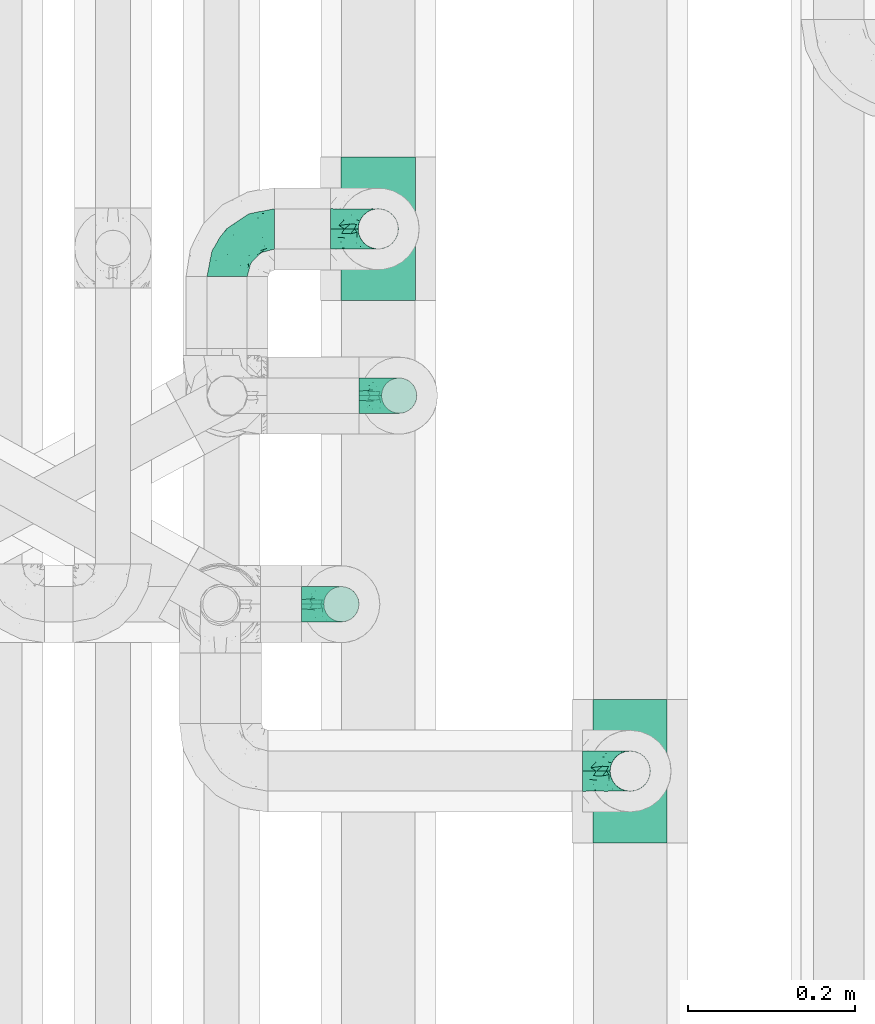
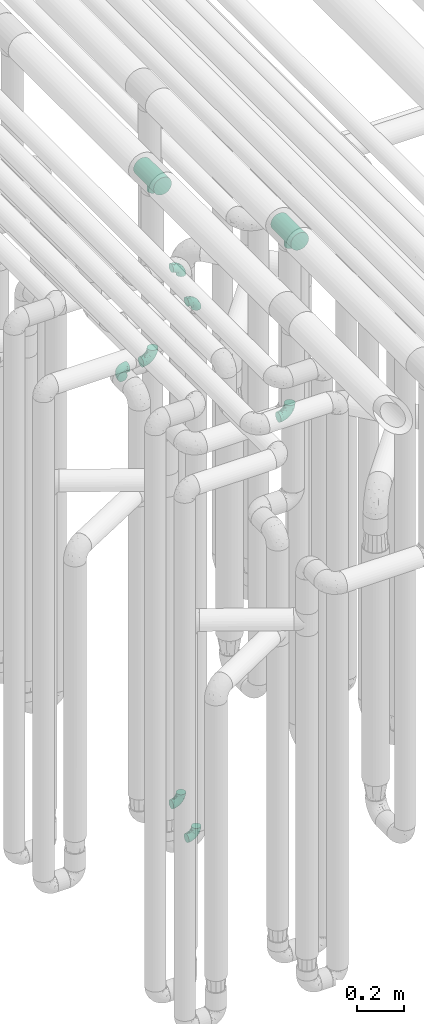
# One storey, part 616 of 827: 9 flow fittings.
"""IFC2X3 building model written with IfcOpenShell, lengths in millimetres."""

import ifcopenshell
import ifcopenshell.guid

model = None  # the IFC model being written
_history = None  # IfcOwnerHistory: only IFC2X3 demands one
_inside = {}  # id of a spatial element -> (the spatial element, [elements in it])
_under = {}  # id of a project, library or spatial element -> (it, [spatial elements below it])
_declared = {}  # id of a project -> (the project, [libraries it declares])
_typed = {}  # id of a type object -> (the type object, [elements of that type])
_made_of = {}  # id of a material, layer set ... -> (it, [elements and type objects made of it])


def new_model(schema):
    """Start an empty IFC model of exactly this schema.

    Asked for "IFC4X3", IfcOpenShell would pick the latest addendum, in which some entities
    have other attributes; the version numbers below select the first issue.
    IFC2X3 requires an IfcOwnerHistory on every rooted entity: one is made here for all.
    """
    global model, _history
    if schema == "IFC4X3":
        model = ifcopenshell.file(schema_version=(4, 3, 0, 0))
    else:
        model = ifcopenshell.file(schema=schema)
    _inside.clear()
    _under.clear()
    _declared.clear()
    _typed.clear()
    _made_of.clear()
    _history = None
    if model.schema == "IFC2X3":
        org = make("IfcOrganization", Name="unknown")
        user = make(
            "IfcPersonAndOrganization",
            ThePerson=make("IfcPerson", FamilyName="unknown"),
            TheOrganization=org,
        )
        app = make(
            "IfcApplication",
            ApplicationDeveloper=org,
            Version="unknown",
            ApplicationFullName="unknown",
            ApplicationIdentifier="unknown",
        )
        _history = make(
            "IfcOwnerHistory",
            OwningUser=user,
            OwningApplication=app,
            ChangeAction="ADDED",
            CreationDate=0,
        )
    return model


def make(cls, **values):
    """One entity of the class cls with the attributes given. An attribute that is None is left unset."""
    return model.create_entity(
        cls, **{name: value for name, value in values.items() if value is not None}
    )


def entity(cls, *values):
    """Any entity or typed value of the class cls, its attributes in the order of the schema. None: left unset."""
    e = model.create_entity(cls)
    for i, value in enumerate(values):
        if value is not None:
            e[i] = value
    return e


def rooted(cls, **values):
    """An entity with a GlobalId (a new one), such as an element, a storey or a relation."""
    return make(cls, GlobalId=ifcopenshell.guid.new(), OwnerHistory=_history, **values)


def si_unit(unit_type, name, prefix=None):
    """IfcSIUnit, for example si_unit("LENGTHUNIT", "METRE", prefix="MILLI")."""
    return make("IfcSIUnit", UnitType=unit_type, Prefix=prefix, Name=name)


def converted_unit(unit_type, name, factor, base, dimensions=None, offset=None):
    """IfcConversionBasedUnit, such as the inch: factor (a typed value) times the base unit."""
    return make(
        "IfcConversionBasedUnit"
        if offset is None
        else "IfcConversionBasedUnitWithOffset",
        ConversionOffset=offset,
        Dimensions=None
        if dimensions is None
        else entity("IfcDimensionalExponents", *dimensions),
        UnitType=unit_type,
        Name=name,
        ConversionFactor=make(
            "IfcMeasureWithUnit", ValueComponent=factor, UnitComponent=base
        ),
    )


def derived_unit(unit_type, elements):
    """IfcDerivedUnit: a product of units, each with its exponent."""
    return make(
        "IfcDerivedUnit",
        Elements=[
            make("IfcDerivedUnitElement", Unit=unit, Exponent=power)
            for unit, power in elements
        ],
        UnitType=unit_type,
    )


def assignment(units):
    """IfcUnitAssignment: the units of a project."""
    return None if units is None else make("IfcUnitAssignment", Units=units)


def point(xyz):
    """IfcCartesianPoint."""
    return None if xyz is None else make("IfcCartesianPoint", Coordinates=xyz)


def direction(xyz):
    """IfcDirection."""
    return None if xyz is None else make("IfcDirection", DirectionRatios=xyz)


def frame(location, z_axis=None, x_axis=None):
    """IfcAxis2Placement3D, a coordinate frame: its origin and axes. An axis left out is left unset."""
    return make(
        "IfcAxis2Placement3D",
        Location=point(location),
        Axis=direction(z_axis),
        RefDirection=direction(x_axis),
    )


def origin():
    """The frame at (0, 0, 0) with its axes left unset."""
    return frame((0.0, 0.0, 0.0))


def place(relative_to, where):
    """IfcLocalPlacement: puts the frame where relative to a parent placement (None: the world)."""
    return make(
        "IfcLocalPlacement", PlacementRelTo=relative_to, RelativePlacement=where
    )


def context(
    kind, dimensions, precision=None, world=None, true_north=None, identifier=None
):
    """IfcGeometricRepresentationContext, for example the 3D "Model" context."""
    return make(
        "IfcGeometricRepresentationContext",
        ContextIdentifier=identifier,
        ContextType=kind,
        CoordinateSpaceDimension=dimensions,
        Precision=precision,
        WorldCoordinateSystem=world,
        TrueNorth=true_north,
    )


def subcontext(parent, identifier, kind, view, scale=None):
    """IfcGeometricRepresentationSubContext, for example "Body" below "Model"."""
    return make(
        "IfcGeometricRepresentationSubContext",
        ContextIdentifier=identifier,
        ContextType=kind,
        ParentContext=parent,
        TargetScale=scale,
        TargetView=view,
    )


def project(units=None, contexts=None):
    """IfcProject with its units and contexts."""
    return rooted(
        "IfcProject",
        Name="project",
        RepresentationContexts=contexts,
        UnitsInContext=assignment(units),
    )


def spatial(cls, under=None, at=None, **own):
    """A site, building, storey or space (cls), placed at a placement, below another one or the project."""
    s = rooted(cls, ObjectPlacement=at, **own)
    if under is not None:
        _under.setdefault(under.id(), (under, []))[1].append(s)
    return s


def faces_of(points, faces, orient=None, outer=None):
    """IfcFace entities. A face is a list of loops; a loop is a list of indices into points, from 0.

    orient and outer hold one flag for each loop. By default every Orientation is true, the
    first loop of a face is its IfcFaceOuterBound and the others are IfcFaceBound.
    """
    made = []
    for i, loops in enumerate(faces):
        bounds = []
        for j, loop in enumerate(loops):
            is_outer = j == 0 if outer is None else outer[i][j]
            bounds.append(
                make(
                    "IfcFaceOuterBound" if is_outer else "IfcFaceBound",
                    Bound=make("IfcPolyLoop", Polygon=[points[k] for k in loop]),
                    Orientation=True if orient is None else orient[i][j],
                )
            )
        made.append(make("IfcFace", Bounds=bounds))
    return made


def faceted_brep(points, faces, orient=None, outer=None, voids=None):
    """IfcFacetedBrep: a solid bounded by flat faces; with voids (closed shells), ...WithVoids."""
    shared = [point(p) for p in points]
    hull = make("IfcClosedShell", CfsFaces=faces_of(shared, faces, orient, outer))
    if voids is None:
        return make("IfcFacetedBrep", Outer=hull)
    return make(
        "IfcFacetedBrepWithVoids",
        Outer=hull,
        Voids=[
            make(cls, CfsFaces=faces_of(shared, fs, o, b)) for cls, fs, o, b in voids
        ],
    )


def shape(context_of_items, identifier, shape_type, items):
    """IfcShapeRepresentation: the items that make up one representation, for example the "Body"."""
    return make(
        "IfcShapeRepresentation",
        ContextOfItems=context_of_items,
        RepresentationIdentifier=identifier,
        RepresentationType=shape_type,
        Items=items,
    )


def source(mapping_origin, context_of_items, identifier, shape_type, items):
    """IfcRepresentationMap: a shape defined once, which mapped items show again and again."""
    return make(
        "IfcRepresentationMap",
        MappingOrigin=mapping_origin,
        MappedRepresentation=shape(context_of_items, identifier, shape_type, items),
    )


def transform(
    local_origin,
    x_axis=None,
    y_axis=None,
    z_axis=None,
    scale=None,
    scale2=None,
    scale3=None,
    uniform=True,
):
    """IfcCartesianTransformationOperator3D, or its non-uniform kind. x_axis, y_axis, z_axis: its Axis1, 2, 3."""
    if uniform:
        return make(
            "IfcCartesianTransformationOperator3D",
            Axis1=direction(x_axis),
            Axis2=direction(y_axis),
            LocalOrigin=point(local_origin),
            Scale=scale,
            Axis3=direction(z_axis),
        )
    return make(
        "IfcCartesianTransformationOperator3DnonUniform",
        Axis1=direction(x_axis),
        Axis2=direction(y_axis),
        LocalOrigin=point(local_origin),
        Scale=scale,
        Axis3=direction(z_axis),
        Scale2=scale2,
        Scale3=scale3,
    )


def mapped(mapping_source, mapping_target):
    """IfcMappedItem: shows the shape of a source again, moved by a transform."""
    return make(
        "IfcMappedItem", MappingSource=mapping_source, MappingTarget=mapping_target
    )


def material(Name=None, Category=None):
    """IfcMaterial."""
    return make("IfcMaterial", Name=Name, Category=Category)


def made_of(thing, what):
    """Note that an element or type object is made of a material, layer set ...; save() writes the relation."""
    if what is not None:
        _made_of.setdefault(what.id(), (what, []))[1].append(thing)
    return thing


def type_object(cls, material=None, **own):
    """A type object (cls), such as IfcWallType, which elements share."""
    return made_of(rooted(cls, **own), material)


def type_shapes(of_type, sources):
    """Give a type object the sources (RepresentationMaps) that its elements show as mapped items."""
    of_type.RepresentationMaps = sources


def element(
    cls,
    number,
    at=None,
    inside=None,
    cuts=None,
    type_object=None,
    material=None,
    context=None,
    identifier="Body",
    shape_type=None,
    held_by="IfcProductDefinitionShape",
    body=None,
    shapes=None,
    **own,
):
    """One element of the class cls, such as IfcWall. Its Tag is "e" and its number.

    at: its placement. inside: the storey or other place that contains it. cuts: it is an
    opening in that element (IfcRelVoidsElement). A single representation is given by context,
    identifier, shape_type and body (its items); several are given by shapes. held_by: the class
    of the entity that holds the representations. save() writes the other relations.
    """
    e = rooted(cls, Tag="e%d" % number, ObjectPlacement=at, **own)
    if body is not None:
        shapes = [shape(context, identifier, shape_type, body)]
    if shapes is not None:
        e.Representation = make(held_by, Representations=shapes)
    if inside is not None:
        _inside.setdefault(inside.id(), (inside, []))[1].append(e)
    if cuts is not None:
        rooted(
            "IfcRelVoidsElement", RelatingBuildingElement=cuts, RelatedOpeningElement=e
        )
    if type_object is not None:
        _typed.setdefault(type_object.id(), (type_object, []))[1].append(e)
    return made_of(e, material)


def aggregate(whole, parts):
    """IfcRelAggregates: a whole, such as a stair, and the parts it consists of."""
    return rooted("IfcRelAggregates", RelatingObject=whole, RelatedObjects=parts)


def save(model, path):
    """Write the relations noted so far, then the file.

    IfcRelAggregates (storeys below a building ...), IfcRelContainedInSpatialStructure (elements
    in a storey), IfcRelDefinesByType, IfcRelAssociatesMaterial and IfcRelDeclares: one each for
    every whole, place, type object, material and project.
    """
    for whole, parts in _under.values():
        aggregate(whole, parts)
    for where, things in _inside.values():
        rooted(
            "IfcRelContainedInSpatialStructure",
            RelatedElements=things,
            RelatingStructure=where,
        )
    for kind, things in _typed.values():
        rooted("IfcRelDefinesByType", RelatedObjects=things, RelatingType=kind)
    for what, things in _made_of.values():
        rooted("IfcRelAssociatesMaterial", RelatedObjects=things, RelatingMaterial=what)
    for by, libraries in _declared.values():
        rooted("IfcRelDeclares", RelatingContext=by, RelatedDefinitions=libraries)
    model.write(path)


model = new_model("IFC2X3")

# Units and contexts
model_context = context("Model", 3, precision=0.01, world=origin(), true_north=direction((6.12303176911189e-17, 1.0)))
body_context = subcontext(model_context, "Body", "Model", "MODEL_VIEW")
ifc_project = project(units=[si_unit("LENGTHUNIT", "METRE", prefix="MILLI"), si_unit("AREAUNIT", "SQUARE_METRE"), si_unit("VOLUMEUNIT", "CUBIC_METRE"), converted_unit("PLANEANGLEUNIT", "DEGREE", entity("IfcRatioMeasure", 0.0174532925199433), si_unit("PLANEANGLEUNIT", "RADIAN"), dimensions=[0, 0, 0, 0, 0, 0, 0]), si_unit("MASSUNIT", "GRAM", prefix="KILO"), derived_unit("MASSDENSITYUNIT", [(si_unit("MASSUNIT", "GRAM", prefix="KILO"), 1), (si_unit("LENGTHUNIT", "METRE"), -3)]), derived_unit("MOMENTOFINERTIAUNIT", [(si_unit("LENGTHUNIT", "METRE"), 4)]), si_unit("TIMEUNIT", "SECOND"), si_unit("FREQUENCYUNIT", "HERTZ"), si_unit("THERMODYNAMICTEMPERATUREUNIT", "DEGREE_CELSIUS"), derived_unit("THERMALTRANSMITTANCEUNIT", [(si_unit("MASSUNIT", "GRAM", prefix="KILO"), 1), (si_unit("THERMODYNAMICTEMPERATUREUNIT", "KELVIN"), -1), (si_unit("TIMEUNIT", "SECOND"), -3)]), derived_unit("VOLUMETRICFLOWRATEUNIT", [(si_unit("LENGTHUNIT", "METRE"), 3), (si_unit("TIMEUNIT", "SECOND"), -1)]), derived_unit("MASSFLOWRATEUNIT", [(si_unit("MASSUNIT", "GRAM", prefix="KILO"), 1), (si_unit("TIMEUNIT", "SECOND"), -1)]), derived_unit("ROTATIONALFREQUENCYUNIT", [(si_unit("TIMEUNIT", "SECOND"), -1)]), si_unit("ELECTRICCURRENTUNIT", "AMPERE"), si_unit("ELECTRICVOLTAGEUNIT", "VOLT"), si_unit("POWERUNIT", "WATT"), si_unit("FORCEUNIT", "NEWTON", prefix="KILO"), si_unit("ILLUMINANCEUNIT", "LUX"), si_unit("LUMINOUSFLUXUNIT", "LUMEN"), si_unit("LUMINOUSINTENSITYUNIT", "CANDELA"), derived_unit("USERDEFINED", [(si_unit("MASSUNIT", "GRAM", prefix="KILO"), -1), (si_unit("LENGTHUNIT", "METRE"), -2), (si_unit("TIMEUNIT", "SECOND"), 3), (si_unit("LUMINOUSFLUXUNIT", "LUMEN"), 1)]), derived_unit("LINEARVELOCITYUNIT", [(si_unit("LENGTHUNIT", "METRE"), 1), (si_unit("TIMEUNIT", "SECOND"), -1)]), si_unit("PRESSUREUNIT", "PASCAL"), derived_unit("USERDEFINED", [(si_unit("LENGTHUNIT", "METRE"), -2), (si_unit("MASSUNIT", "GRAM", prefix="KILO"), 1), (si_unit("TIMEUNIT", "SECOND"), -2)]), derived_unit("LINEARFORCEUNIT", [(si_unit("MASSUNIT", "GRAM", prefix="KILO"), 1), (si_unit("LENGTHUNIT", "METRE"), 1), (si_unit("TIMEUNIT", "SECOND"), -2), (si_unit("LENGTHUNIT", "METRE"), -1)]), derived_unit("PLANARFORCEUNIT", [(si_unit("MASSUNIT", "GRAM", prefix="KILO"), 1), (si_unit("LENGTHUNIT", "METRE"), 1), (si_unit("TIMEUNIT", "SECOND"), -2), (si_unit("LENGTHUNIT", "METRE"), -2)])], contexts=[model_context])

# Site, building, storey
site_placement = place(None, origin())
site = spatial("IfcSite", under=ifc_project, at=site_placement, CompositionType="ELEMENT")
building_placement = place(site_placement, origin())
building = spatial("IfcBuilding", under=site, at=building_placement, CompositionType="ELEMENT")
storey_placement = place(building_placement, frame((0.0, 0.0, 28200.0)))
storey = spatial("IfcBuildingStorey", under=building, at=storey_placement, Name="08", CompositionType="ELEMENT", Elevation=28200.0)

# Flow fittings
ifc_material = material()
pipe_fitting_type_1 = type_object("IfcPipeFittingType", Name="ADSK_1", PredefinedType="NOTDEFINED", material=ifc_material)
shared_shape_1 = source(origin(), body_context, "Body", "Brep", [
    faceted_brep([(-57.0, 12.07, -20.91), (-57.0, 6.25, -23.33), (-57.0, 0.0, -24.15), (-57.0, -6.25, -23.33), (-57.0, -12.08, -20.91), (-57.0, -17.08, -17.08), (-57.0, -20.91, -12.08), (-57.0, -23.33, -6.25), (-57.0, -24.15, 0.0), (-57.0, -23.33, 6.25), (-57.0, -20.91, 12.07), (-57.0, -17.08, 17.08), (-57.0, -12.08, 20.91), (-57.0, -6.25, 23.33), (-57.0, 0.0, 24.15), (-57.0, 6.25, 23.33), (-57.0, 12.07, 20.91), (-57.0, 17.08, 17.08), (-57.0, 20.91, 12.07), (-57.0, 23.33, 6.25), (-57.0, 24.15, 0.0), (-57.0, 23.33, -6.25), (-57.0, 20.91, -12.08), (-57.0, 17.08, -17.08), (0.0, 57.0, -24.15), (-6.25, 57.0, -23.33), (-12.07, 57.0, -20.91), (-17.08, 57.0, -17.08), (-20.91, 57.0, -12.08), (-23.33, 57.0, -6.25), (-24.15, 57.0, 0.0), (-23.33, 57.0, 6.25), (-20.91, 57.0, 12.07), (-17.08, 57.0, 17.08), (-12.07, 57.0, 20.91), (-6.25, 57.0, 23.33), (0.0, 57.0, 24.15), (6.25, 57.0, 23.33), (12.08, 57.0, 20.91), (17.08, 57.0, 17.08), (20.91, 57.0, 12.07), (23.33, 57.0, 6.25), (24.15, 57.0, 0.0), (23.33, 57.0, -6.25), (20.91, 57.0, -12.08), (17.08, 57.0, -17.08), (12.08, 57.0, -20.91), (6.25, 57.0, -23.33), (14.9, 21.14, 6.17), (13.61, 24.64, 12.48), (6.23, 8.95, 8.98), (-41.47, -21.06, 0.0), (-41.92, -18.38, 13.72), (-24.64, -13.61, 12.48), (-37.37, -13.24, 18.15), (-6.8, -4.93, 8.18), (-21.76, -15.19, 6.22), (-12.78, -9.18, 0.0), (-37.73, -20.51, 7.75), (-7.38, 7.38, 20.24), (-23.37, -4.26, 20.42), (-11.9, -3.19, 15.86), (-42.14, -8.7, 21.82), (13.24, 37.37, 18.15), (9.33, 23.53, 16.85), (4.26, 23.37, 20.42), (2.77, 10.92, 15.55), (-29.46, 0.91, 23.52), (-44.13, 20.56, 15.69), (-39.25, 26.33, 10.88), (-49.02, 22.92, 9.96), (-34.58, 23.87, 17.15), (-15.8, 6.8, 22.81), (-8.67, 20.47, 23.88), (-18.12, 12.9, 24.08), (-48.29, 14.92, 19.65), (-44.06, -2.85, 23.78), (-9.23, 48.95, 22.58), (-3.78, 42.74, 24.07), (-40.34, 4.26, 24.09), (-44.02, 26.14, 5.46), (-44.04, 9.88, 22.74), (-4.95, 16.87, 22.52), (-2.75, 1.43, 12.5), (-25.48, 40.98, 10.71), (20.51, 37.73, 7.75), (18.38, 41.92, 13.72), (8.7, 42.14, 21.82), (-25.95, -17.97, 0.0), (2.85, 44.06, 23.78), (21.06, 41.47, 0.0), (17.97, 25.95, 0.0), (-24.04, -9.27, 17.13), (-33.26, 33.26, 5.86), (-28.55, 40.57, 0.0), (-40.57, 28.55, 0.0), (-25.29, 47.19, 4.06), (-27.01, 31.1, 16.77), (-15.7, 43.95, 19.9), (-20.27, 45.22, 15.61), (-30.53, 31.98, 12.64), (-11.28, 38.33, 22.92), (-9.97, 27.88, 24.09), (-20.15, 30.26, 21.25), (-31.25, 11.75, 23.64), (-28.75, 7.23, 24.15), (-29.53, 18.06, 22.27), (-28.44, 24.21, 20.02), (-37.55, 17.7, 20.26), (-15.88, 29.25, 22.99), (-20.82, 20.82, 23.44), (-0.91, 29.46, 23.52), (-13.5, -7.67, 12.04), (1.49, 1.56, 5.16), (8.86, 10.35, 4.59), (0.38, -0.38, 0.0), (9.18, 12.78, 0.0), (-37.37, -13.24, -18.15), (8.86, 10.35, -4.59), (-45.22, 20.27, -15.61), (-43.95, 15.7, -19.9), (-38.33, 11.28, -22.92), (-48.95, 9.23, -22.58), (-47.19, 25.29, -4.06), (-33.26, 33.26, -5.86), (18.38, 41.92, -13.72), (-30.26, 20.15, -21.25), (2.85, 44.06, -23.78), (-4.26, 40.34, -24.09), (-40.98, 25.48, -10.71), (-41.92, -18.38, -13.72), (9.25, 23.5, -16.92), (4.26, 23.37, -20.42), (13.24, 37.37, -18.15), (-37.73, -20.51, -7.75), (-11.75, 31.25, -23.64), (-7.23, 28.75, -24.15), (-12.9, 18.12, -24.08), (8.7, 42.14, -21.82), (-44.06, -2.85, -23.78), (-6.8, 15.8, -22.81), (-20.47, 8.67, -23.88), (-24.64, -13.61, -12.48), (-42.74, 3.78, -24.07), (-18.06, 29.53, -22.27), (-24.21, 28.44, -20.02), (-27.88, 9.97, -24.09), (-31.1, 27.01, -16.77), (-26.14, 44.02, -5.46), (14.9, 21.14, -6.17), (20.51, 37.73, -7.75), (-9.88, 44.04, -22.74), (-20.56, 44.13, -15.69), (-21.76, -15.19, -6.22), (-13.5, -7.67, -12.04), (-24.14, -9.76, -16.74), (-11.9, -3.19, -15.86), (-14.92, 48.29, -19.65), (-23.37, -4.26, -20.42), (-0.91, 29.46, -23.52), (-26.33, 39.25, -10.88), (-23.87, 34.58, -17.15), (-42.14, -8.7, -21.82), (-22.92, 49.02, -9.96), (13.61, 24.64, -12.48), (-31.98, 30.53, -12.64), (-16.87, 4.95, -22.52), (-17.7, 37.55, -20.26), (-29.25, 15.88, -22.99), (-20.82, 20.82, -23.44), (-29.46, 0.91, -23.52), (-7.38, 7.38, -20.24), (2.77, 10.92, -15.55), (6.23, 8.95, -8.98), (-6.8, -4.93, -8.18), (-2.81, 1.41, -12.54), (1.49, 1.56, -5.16)], [[[0, 1, 2, 3, 4, 5, 6, 7, 8, 9, 10, 11, 12, 13, 14, 15, 16, 17, 18, 19, 20, 21, 22, 23]], [[24, 25, 26, 27, 28, 29, 30, 31, 32, 33, 34, 35, 36, 37, 38, 39, 40, 41, 42, 43, 44, 45, 46, 47]], [[48, 49, 50]], [[9, 8, 51]], [[52, 53, 54]], [[55, 56, 57]], [[10, 58, 52]], [[9, 58, 10]], [[59, 60, 61]], [[54, 12, 11]], [[54, 62, 12]], [[63, 39, 38]], [[64, 65, 66]], [[62, 60, 67]], [[68, 69, 70]], [[71, 69, 68]], [[72, 73, 74]], [[16, 75, 17]], [[13, 76, 14]], [[35, 77, 78]], [[14, 79, 15]], [[17, 68, 18]], [[14, 76, 79]], [[20, 19, 80]], [[70, 19, 18]], [[81, 15, 79]], [[15, 81, 16]], [[73, 72, 82]], [[66, 83, 50]], [[32, 31, 84]], [[85, 86, 49]], [[63, 87, 65]], [[56, 58, 88]], [[36, 89, 37]], [[85, 41, 40]], [[36, 35, 78]], [[90, 41, 85]], [[40, 39, 86]], [[12, 62, 13]], [[86, 85, 40]], [[48, 85, 49]], [[85, 91, 90]], [[87, 38, 37]], [[92, 60, 54]], [[80, 69, 93]], [[93, 94, 95]], [[10, 52, 11]], [[94, 96, 30]], [[97, 98, 99]], [[80, 93, 95]], [[100, 97, 84]], [[99, 98, 33]], [[101, 102, 78]], [[103, 101, 98]], [[96, 31, 30]], [[77, 98, 101]], [[77, 35, 34]], [[34, 33, 98]], [[9, 51, 58]], [[87, 63, 38]], [[104, 105, 74]], [[106, 103, 107]], [[106, 81, 104]], [[75, 68, 17]], [[108, 107, 71]], [[33, 32, 99]], [[109, 103, 110]], [[101, 109, 102]], [[89, 78, 111]], [[53, 52, 58]], [[54, 11, 52]], [[60, 62, 54]], [[88, 58, 51]], [[76, 62, 67]], [[53, 112, 92]], [[60, 59, 72]], [[39, 63, 86]], [[49, 86, 63]], [[89, 87, 37]], [[42, 41, 90]], [[111, 82, 65]], [[111, 65, 87]], [[65, 59, 66]], [[104, 81, 79]], [[75, 81, 108]], [[32, 84, 99]], [[97, 99, 84]], [[98, 97, 103]], [[106, 107, 108]], [[74, 102, 110]], [[111, 78, 102]], [[74, 110, 104]], [[74, 67, 72]], [[61, 92, 112]], [[66, 59, 61]], [[56, 53, 58]], [[66, 50, 49]], [[61, 112, 83]], [[66, 49, 64]], [[78, 89, 36]], [[87, 89, 111]], [[62, 76, 13]], [[79, 76, 67]], [[100, 93, 69]], [[96, 93, 84]], [[55, 113, 50]], [[113, 114, 50]], [[104, 79, 105]], [[106, 104, 110]], [[20, 80, 95]], [[85, 48, 91]], [[115, 114, 113]], [[116, 91, 48]], [[70, 80, 19]], [[93, 96, 94]], [[84, 31, 96]], [[103, 106, 110]], [[81, 106, 108]], [[103, 97, 107]], [[71, 107, 97]], [[71, 97, 100]], [[108, 71, 68]], [[79, 67, 105]], [[67, 74, 105]], [[115, 113, 57]], [[112, 56, 55]], [[56, 88, 57]], [[60, 72, 67]], [[82, 72, 59]], [[65, 82, 59]], [[82, 111, 73]], [[111, 102, 73]], [[102, 74, 73]], [[81, 75, 16]], [[68, 75, 108]], [[68, 70, 18]], [[80, 70, 69]], [[98, 77, 34]], [[78, 77, 101]], [[93, 100, 84]], [[71, 100, 69]], [[102, 109, 110]], [[101, 103, 109]], [[53, 92, 54]], [[61, 60, 92]], [[56, 112, 53]], [[83, 112, 55]], [[50, 83, 55]], [[61, 83, 66]], [[49, 63, 64]], [[65, 64, 63]], [[57, 113, 55]], [[114, 115, 116]], [[116, 48, 114]], [[48, 50, 114]], [[117, 5, 4]], [[116, 115, 118]], [[119, 120, 23]], [[121, 122, 120]], [[95, 123, 20]], [[0, 23, 120]], [[124, 95, 94]], [[125, 45, 44]], [[121, 120, 126]], [[24, 127, 128]], [[22, 21, 129]], [[0, 122, 1]], [[5, 117, 130]], [[131, 132, 133]], [[134, 88, 51]], [[135, 136, 137]], [[6, 5, 130]], [[46, 138, 47]], [[139, 3, 2]], [[140, 141, 137]], [[6, 134, 7]], [[134, 130, 142]], [[143, 2, 1]], [[144, 126, 145]], [[121, 146, 143]], [[147, 120, 119]], [[94, 148, 124]], [[149, 150, 91]], [[30, 29, 148]], [[151, 25, 128]], [[27, 152, 28]], [[134, 153, 88]], [[154, 155, 156]], [[27, 26, 157]], [[151, 26, 25]], [[155, 158, 156]], [[24, 47, 127]], [[1, 122, 143]], [[138, 132, 159]], [[160, 152, 161]], [[24, 128, 25]], [[46, 133, 138]], [[162, 117, 4]], [[148, 160, 124]], [[152, 160, 163]], [[154, 142, 155]], [[45, 125, 133]], [[133, 46, 45]], [[125, 164, 133]], [[51, 7, 134]], [[42, 90, 43]], [[165, 147, 129]], [[153, 134, 142]], [[43, 150, 44]], [[162, 4, 3]], [[141, 140, 166]], [[117, 162, 158]], [[163, 29, 28]], [[43, 90, 150]], [[123, 21, 20]], [[144, 151, 135]], [[157, 152, 27]], [[167, 145, 161]], [[23, 22, 119]], [[168, 126, 169]], [[121, 168, 146]], [[139, 143, 170]], [[142, 130, 117]], [[8, 7, 51]], [[134, 6, 130]], [[139, 162, 3]], [[170, 166, 158]], [[170, 158, 162]], [[158, 171, 156]], [[44, 150, 125]], [[91, 150, 90]], [[164, 125, 150]], [[132, 138, 133]], [[127, 138, 159]], [[131, 164, 172]], [[132, 171, 140]], [[135, 151, 128]], [[157, 151, 167]], [[22, 129, 119]], [[147, 119, 129]], [[120, 147, 126]], [[144, 145, 167]], [[137, 146, 169]], [[170, 143, 146]], [[137, 169, 135]], [[137, 159, 140]], [[171, 172, 156]], [[173, 174, 175]], [[156, 175, 154]], [[174, 57, 153]], [[132, 172, 171]], [[172, 164, 173]], [[143, 139, 2]], [[162, 139, 170]], [[138, 127, 47]], [[128, 127, 159]], [[165, 124, 160]], [[123, 124, 129]], [[149, 173, 164]], [[176, 174, 173]], [[135, 128, 136]], [[144, 135, 169]], [[150, 149, 164]], [[176, 118, 115]], [[149, 91, 116]], [[30, 148, 94]], [[163, 148, 29]], [[124, 123, 95]], [[129, 21, 123]], [[126, 144, 169]], [[151, 144, 167]], [[126, 147, 145]], [[161, 145, 147]], [[161, 147, 165]], [[167, 161, 152]], [[128, 159, 136]], [[159, 137, 136]], [[154, 153, 142]], [[132, 140, 159]], [[174, 176, 57]], [[57, 88, 153]], [[166, 140, 171]], [[158, 166, 171]], [[166, 170, 141]], [[170, 146, 141]], [[146, 137, 141]], [[151, 157, 26]], [[152, 157, 167]], [[152, 163, 28]], [[148, 163, 160]], [[120, 122, 0]], [[143, 122, 121]], [[124, 165, 129]], [[161, 165, 160]], [[146, 168, 169]], [[121, 126, 168]], [[142, 117, 155]], [[158, 155, 117]], [[175, 156, 172]], [[153, 154, 174]], [[173, 175, 172]], [[174, 154, 175]], [[164, 131, 133]], [[172, 132, 131]], [[176, 173, 118]], [[57, 176, 115]], [[173, 149, 118]], [[149, 116, 118]]]),
])
type_shapes(pipe_fitting_type_1, [shared_shape_1])
for number, where, z_axis, x_axis, name in (
    (1, (35736.85, 12006.08, 2600.0), (0.0, 0.0, 1.0), (-1.0, 0.0, 0.0), "ADSK_1"),
    (2, (36220.03, 11356.08, 2600.0), (0.0, -1.0, 0.0), (1.0, 0.0, 0.0), "ADSK_1"),
    (3, (35918.07, 12006.08, 2600.0), (0.0, -1.0, 0.0), (1.0, 0.0, 0.0), "ADSK_1"),
):
    element("IfcFlowFitting", number, at=place(storey_placement, frame(where, z_axis=z_axis, x_axis=x_axis)), inside=storey, type_object=pipe_fitting_type_1, material=ifc_material, Name=name, ObjectType="ADSK_1", context=body_context, shape_type="MappedRepresentation", body=[
        mapped(shared_shape_1, transform((0.0, 0.0, 0.0), scale=1.0)),
    ])
pipe_fitting_type_2 = type_object("IfcPipeFittingType", Name="ADSK_1", PredefinedType="NOTDEFINED", material=ifc_material)
shared_shape_2 = source(origin(), body_context, "Body", "Brep", [
    faceted_brep([(-48.0, 10.6, -18.36), (-48.0, 5.49, -20.48), (-48.0, 0.0, -21.2), (-48.0, -5.49, -20.48), (-48.0, -10.6, -18.36), (-48.0, -14.99, -14.99), (-48.0, -18.36, -10.6), (-48.0, -20.48, -5.49), (-48.0, -21.2, 0.0), (-48.0, -20.48, 5.49), (-48.0, -18.36, 10.6), (-48.0, -14.99, 14.99), (-48.0, -10.6, 18.36), (-48.0, -5.49, 20.48), (-48.0, 0.0, 21.2), (-48.0, 5.49, 20.48), (-48.0, 10.6, 18.36), (-48.0, 14.99, 14.99), (-48.0, 18.36, 10.6), (-48.0, 20.48, 5.49), (-48.0, 21.2, 0.0), (-48.0, 20.48, -5.49), (-48.0, 18.36, -10.6), (-48.0, 14.99, -14.99), (0.0, 48.0, -21.2), (-5.49, 48.0, -20.48), (-10.6, 48.0, -18.36), (-14.99, 48.0, -14.99), (-18.36, 48.0, -10.6), (-20.48, 48.0, -5.49), (-21.2, 48.0, 0.0), (-20.48, 48.0, 5.49), (-18.36, 48.0, 10.6), (-14.99, 48.0, 14.99), (-10.6, 48.0, 18.36), (-5.49, 48.0, 20.48), (0.0, 48.0, 21.2), (5.49, 48.0, 20.48), (10.6, 48.0, 18.36), (14.99, 48.0, 14.99), (18.36, 48.0, 10.6), (20.48, 48.0, 5.49), (21.2, 48.0, 0.0), (20.48, 48.0, -5.49), (18.36, 48.0, -10.6), (14.99, 48.0, -14.99), (10.6, 48.0, -18.36), (5.49, 48.0, -20.48), (-35.25, -16.22, 12.01), (-34.76, -18.57, 0.0), (-20.87, -12.37, 10.9), (-31.49, -11.78, 15.9), (-37.0, -2.58, 20.86), (-33.89, 3.62, 21.15), (-31.81, -18.14, 6.76), (-5.78, 5.78, 17.67), (-19.42, -4.1, 17.86), (-9.6, -3.39, 13.73), (-35.44, -7.73, 19.13), (11.78, 31.49, 15.9), (-5.93, -5.46, 6.95), (-18.45, -13.78, 5.46), (-10.29, -8.43, 0.0), (-24.6, 0.55, 20.62), (-37.28, 17.94, 13.81), (-33.38, 22.85, 9.59), (-41.46, 20.06, 8.75), (-29.51, 20.45, 15.16), (-15.04, 10.79, 21.13), (-7.08, 16.98, 20.93), (-8.39, 23.51, 21.15), (-40.86, 13.03, 17.26), (-8.05, 41.26, 19.83), (-3.21, 35.97, 21.14), (8.53, 19.66, 14.74), (4.1, 19.42, 17.86), (-37.72, 22.66, 4.78), (-37.07, 8.58, 19.98), (-13.0, 5.43, 19.97), (-3.78, 13.93, 19.7), (3.02, 8.69, 13.43), (-2.27, -0.05, 10.65), (6.22, 6.99, 7.09), (-22.25, 34.6, 9.45), (18.14, 31.81, 6.76), (16.22, 35.25, 12.01), (12.37, 20.87, 10.9), (7.73, 35.44, 19.13), (-21.52, -15.93, 0.0), (2.58, 37.0, 20.86), (18.57, 34.76, 0.0), (13.78, 18.45, 5.46), (15.93, 21.52, 0.0), (-20.03, -8.54, 14.9), (-28.6, 28.6, 5.16), (-24.79, 34.6, 0.0), (-34.6, 24.79, 0.0), (-22.81, 37.41, 4.68), (-23.36, 26.33, 14.79), (-13.68, 37.05, 17.49), (-17.72, 38.12, 13.73), (-26.25, 27.3, 11.24), (-9.71, 32.34, 20.14), (-17.26, 25.6, 18.71), (-26.33, 9.99, 20.77), (-24.06, 6.05, 21.2), (-25.02, 15.46, 19.56), (-24.3, 20.72, 17.57), (-31.95, 15.23, 17.8), (-13.53, 24.7, 20.21), (-17.6, 17.6, 20.6), (-0.55, 24.6, 20.62), (-11.41, -7.48, 10.43), (0.93, -0.93, 0.0), (8.43, 10.29, 0.0), (-11.41, -7.48, -10.43), (-20.1, -8.84, -14.66), (-9.6, -3.39, -13.73), (7.73, 35.44, -19.13), (4.1, 19.42, -17.86), (-0.55, 24.6, -20.62), (-38.12, 17.72, -13.73), (-37.05, 13.68, -17.49), (-32.34, 9.71, -20.14), (-41.26, 8.05, -19.83), (-37.41, 22.81, -4.68), (-23.51, 8.39, -21.15), (-35.97, 3.21, -21.14), (-28.6, 28.6, -5.16), (-31.81, -18.14, -6.76), (-18.45, -13.78, -5.46), (-25.6, 17.26, -18.71), (-19.42, -4.1, -17.86), (-17.94, 37.28, -13.81), (-22.85, 33.38, -9.59), (-20.06, 41.46, -8.75), (-31.49, -11.78, -15.9), (-35.25, -16.22, -12.01), (8.53, 19.66, -14.74), (11.78, 31.49, -15.9), (-9.99, 26.33, -20.77), (-6.05, 24.06, -21.2), (-10.79, 15.04, -21.13), (-37.0, -2.58, -20.86), (-16.98, 7.08, -20.93), (-5.43, 13.0, -19.97), (-13.93, 3.78, -19.7), (-20.87, -12.37, -10.9), (-26.33, 23.36, -14.79), (-22.66, 37.72, -4.78), (13.78, 18.45, -5.46), (18.14, 31.81, -6.76), (-15.46, 25.02, -19.56), (-20.72, 24.3, -17.57), (16.22, 35.25, -12.01), (-13.03, 40.86, -17.26), (-8.58, 37.07, -19.98), (2.58, 37.0, -20.86), (-3.62, 33.89, -21.15), (-34.6, 22.25, -9.45), (6.22, 6.99, -7.09), (-20.45, 29.51, -15.16), (-35.44, -7.73, -19.13), (12.37, 20.87, -10.9), (-27.3, 26.25, -11.24), (-15.23, 31.95, -17.8), (-24.7, 13.53, -20.21), (-24.6, 0.55, -20.62), (-5.78, 5.78, -17.67), (-17.6, 17.6, -20.6), (3.02, 8.69, -13.43), (-5.93, -5.46, -6.95), (-2.27, -0.05, -10.65)], [[[0, 1, 2, 3, 4, 5, 6, 7, 8, 9, 10, 11, 12, 13, 14, 15, 16, 17, 18, 19, 20, 21, 22, 23]], [[24, 25, 26, 27, 28, 29, 30, 31, 32, 33, 34, 35, 36, 37, 38, 39, 40, 41, 42, 43, 44, 45, 46, 47]], [[10, 48, 11]], [[9, 8, 49]], [[48, 50, 51]], [[14, 52, 53]], [[10, 54, 48]], [[9, 54, 10]], [[55, 56, 57]], [[51, 12, 11]], [[51, 58, 12]], [[59, 39, 38]], [[60, 61, 62]], [[58, 56, 63]], [[64, 65, 66]], [[67, 65, 64]], [[68, 69, 70]], [[16, 71, 17]], [[13, 52, 14]], [[35, 72, 73]], [[14, 53, 15]], [[17, 64, 18]], [[74, 59, 75]], [[20, 19, 76]], [[66, 19, 18]], [[77, 15, 53]], [[15, 77, 16]], [[69, 78, 79]], [[80, 81, 82]], [[32, 31, 83]], [[84, 85, 86]], [[59, 87, 75]], [[61, 54, 88]], [[36, 89, 37]], [[84, 41, 40]], [[36, 35, 73]], [[90, 41, 84]], [[40, 39, 85]], [[12, 58, 13]], [[85, 84, 40]], [[91, 84, 86]], [[84, 92, 90]], [[87, 38, 37]], [[93, 56, 51]], [[65, 94, 76]], [[94, 95, 96]], [[84, 91, 92]], [[95, 97, 30]], [[98, 99, 100]], [[76, 94, 96]], [[101, 98, 83]], [[100, 99, 33]], [[102, 70, 73]], [[103, 102, 99]], [[94, 97, 95]], [[72, 99, 102]], [[72, 35, 34]], [[34, 33, 99]], [[9, 49, 54]], [[87, 59, 38]], [[104, 105, 68]], [[106, 103, 107]], [[106, 77, 104]], [[71, 64, 17]], [[108, 107, 67]], [[33, 32, 100]], [[109, 103, 110]], [[102, 109, 70]], [[89, 73, 111]], [[50, 48, 54]], [[51, 11, 48]], [[56, 58, 51]], [[88, 54, 49]], [[52, 58, 63]], [[50, 112, 93]], [[56, 55, 78]], [[39, 59, 85]], [[86, 85, 59]], [[89, 87, 37]], [[42, 41, 90]], [[111, 79, 75]], [[111, 75, 87]], [[75, 55, 80]], [[104, 77, 53]], [[71, 77, 108]], [[32, 83, 100]], [[98, 100, 83]], [[99, 98, 103]], [[106, 107, 108]], [[68, 70, 110]], [[111, 73, 70]], [[68, 110, 104]], [[68, 63, 78]], [[57, 93, 112]], [[80, 55, 57]], [[61, 50, 54]], [[80, 82, 86]], [[81, 57, 112]], [[74, 86, 59]], [[60, 113, 82]], [[82, 114, 91]], [[101, 94, 65]], [[97, 94, 83]], [[73, 89, 36]], [[87, 89, 111]], [[58, 52, 13]], [[53, 52, 63]], [[104, 53, 105]], [[106, 104, 110]], [[20, 76, 96]], [[76, 19, 66]], [[103, 106, 110]], [[77, 106, 108]], [[103, 98, 107]], [[67, 107, 98]], [[67, 98, 101]], [[108, 67, 64]], [[53, 63, 105]], [[63, 68, 105]], [[83, 31, 97]], [[30, 97, 31]], [[62, 113, 60]], [[112, 61, 60]], [[61, 88, 62]], [[86, 82, 91]], [[56, 78, 63]], [[114, 82, 113]], [[114, 92, 91]], [[79, 78, 55]], [[75, 79, 55]], [[69, 79, 111]], [[70, 69, 111]], [[78, 69, 68]], [[77, 71, 16]], [[64, 71, 108]], [[64, 66, 18]], [[76, 66, 65]], [[99, 72, 34]], [[73, 72, 102]], [[94, 101, 83]], [[67, 101, 65]], [[75, 80, 74]], [[80, 86, 74]], [[70, 109, 110]], [[102, 103, 109]], [[50, 93, 51]], [[57, 56, 93]], [[61, 112, 50]], [[81, 112, 60]], [[82, 81, 60]], [[80, 57, 81]], [[115, 116, 117]], [[118, 119, 120]], [[121, 122, 23]], [[123, 124, 122]], [[96, 125, 20]], [[123, 126, 127]], [[128, 96, 95]], [[129, 130, 88]], [[123, 122, 131]], [[116, 132, 117]], [[133, 134, 135]], [[0, 124, 1]], [[5, 136, 137]], [[138, 119, 139]], [[129, 88, 49]], [[140, 141, 142]], [[6, 5, 137]], [[46, 118, 47]], [[143, 3, 2]], [[144, 145, 146]], [[6, 129, 7]], [[129, 137, 147]], [[127, 2, 1]], [[148, 122, 121]], [[128, 125, 96]], [[134, 128, 149]], [[95, 149, 128]], [[150, 151, 92]], [[30, 29, 149]], [[152, 131, 153]], [[27, 133, 28]], [[154, 45, 44]], [[136, 5, 4]], [[27, 26, 155]], [[156, 26, 25]], [[24, 157, 158]], [[24, 47, 157]], [[22, 21, 159]], [[160, 150, 114]], [[134, 133, 161]], [[142, 144, 126]], [[46, 139, 118]], [[162, 136, 4]], [[156, 25, 158]], [[1, 124, 127]], [[115, 147, 116]], [[45, 154, 139]], [[139, 46, 45]], [[154, 163, 139]], [[162, 4, 3]], [[42, 90, 43]], [[130, 129, 147]], [[49, 7, 129]], [[43, 151, 44]], [[0, 23, 122]], [[24, 158, 25]], [[136, 162, 132]], [[135, 29, 28]], [[43, 90, 151]], [[164, 148, 159]], [[152, 156, 140]], [[155, 133, 27]], [[165, 153, 161]], [[23, 22, 121]], [[123, 131, 166]], [[123, 166, 126]], [[143, 127, 167]], [[147, 137, 136]], [[8, 7, 49]], [[129, 6, 137]], [[143, 162, 3]], [[167, 146, 132]], [[167, 132, 162]], [[132, 168, 117]], [[44, 151, 154]], [[92, 151, 90]], [[163, 154, 151]], [[119, 118, 139]], [[157, 118, 120]], [[138, 139, 163]], [[119, 168, 145]], [[140, 156, 158]], [[155, 156, 165]], [[22, 159, 121]], [[148, 121, 159]], [[122, 148, 131]], [[152, 153, 165]], [[142, 126, 169]], [[167, 127, 126]], [[142, 169, 140]], [[142, 120, 145]], [[168, 170, 117]], [[160, 171, 172]], [[115, 172, 171]], [[171, 62, 130]], [[119, 170, 168]], [[170, 163, 160]], [[150, 163, 151]], [[113, 171, 160]], [[164, 128, 134]], [[125, 128, 159]], [[127, 143, 2]], [[162, 143, 167]], [[118, 157, 47]], [[158, 157, 120]], [[140, 158, 141]], [[152, 140, 169]], [[30, 149, 95]], [[149, 29, 135]], [[131, 152, 169]], [[156, 152, 165]], [[131, 148, 153]], [[161, 153, 148]], [[161, 148, 164]], [[165, 161, 133]], [[158, 120, 141]], [[120, 142, 141]], [[159, 21, 125]], [[20, 125, 21]], [[115, 130, 147]], [[114, 113, 160]], [[62, 171, 113]], [[62, 88, 130]], [[160, 163, 150]], [[150, 92, 114]], [[119, 145, 120]], [[146, 145, 168]], [[132, 146, 168]], [[144, 146, 167]], [[126, 144, 167]], [[145, 144, 142]], [[156, 155, 26]], [[133, 155, 165]], [[133, 135, 28]], [[149, 135, 134]], [[122, 124, 0]], [[127, 124, 123]], [[128, 164, 159]], [[161, 164, 134]], [[163, 170, 138]], [[170, 119, 138]], [[131, 169, 166]], [[126, 166, 169]], [[147, 136, 116]], [[132, 116, 136]], [[172, 115, 117]], [[130, 115, 171]], [[117, 170, 172]], [[160, 172, 170]]]),
])
type_shapes(pipe_fitting_type_2, [shared_shape_2])
for number, where, z_axis, x_axis, name in (
    (4, (35943.05, 11806.2, 400.0), (0.0, -1.0, 0.0), (1.0, 0.0, 0.0), "ADSK_1"),
    (5, (35943.05, 11806.2, 3200.0), (0.0, -1.0, 0.0), (0.0, 0.0, 1.0), "ADSK_1"),
    (6, (35873.78, 11556.17, 3200.0), (0.0, 1.0, 0.0), (1.0, 0.0, 0.0), "ADSK_1"),
    (7, (35873.78, 11556.17, 400.0), (0.0, -1.0, 0.0), (1.0, 0.0, 0.0), "ADSK_1"),
):
    element("IfcFlowFitting", number, at=place(storey_placement, frame(where, z_axis=z_axis, x_axis=x_axis)), inside=storey, type_object=pipe_fitting_type_2, material=ifc_material, Name=name, ObjectType="ADSK_1", context=body_context, shape_type="MappedRepresentation", body=[
        mapped(shared_shape_2, transform((0.0, 0.0, 0.0), scale=1.0)),
    ])
pipe_fitting_type_3 = type_object("IfcPipeFittingType", Name="ADSK_1", PredefinedType="NOTDEFINED", material=ifc_material)
shared_shape_3 = source(origin(), body_context, "Body", "Brep", [
    faceted_brep([(-86.0, 22.22, -38.49), (-86.0, 11.5, -42.94), (-86.0, 0.0, -44.45), (-86.0, -11.5, -42.94), (-86.0, -22.23, -38.49), (-86.0, -31.43, -31.43), (-86.0, -38.49, -22.23), (-86.0, -42.94, -11.5), (-86.0, -44.45, 0.0), (-86.0, -42.94, 11.5), (-86.0, -38.49, 22.22), (-86.0, -31.43, 31.43), (-86.0, -22.23, 38.49), (-86.0, -11.5, 42.94), (-86.0, 0.0, 44.45), (-86.0, 11.5, 42.94), (-86.0, 22.22, 38.49), (-86.0, 31.43, 31.43), (-86.0, 38.49, 22.22), (-86.0, 42.94, 11.5), (-86.0, 44.45, 0.0), (-86.0, 42.94, -11.5), (-86.0, 38.49, -22.23), (-86.0, 31.43, -31.43), (86.0, 0.0, -44.45), (86.0, 11.5, -42.94), (86.0, 22.22, -38.49), (86.0, 31.43, -31.43), (86.0, 38.49, -22.23), (86.0, 42.94, -11.5), (86.0, 44.45, 0.0), (86.0, 42.94, 11.5), (86.0, 38.49, 22.22), (86.0, 31.43, 31.43), (86.0, 22.22, 38.49), (86.0, 11.5, 42.94), (86.0, 0.0, 44.45), (86.0, -11.5, 42.94), (86.0, -22.23, 38.49), (86.0, -31.43, 31.43), (86.0, -38.49, 22.22), (86.0, -42.94, 11.5), (86.0, -44.45, 0.0), (86.0, -42.94, -11.5), (86.0, -38.49, -22.23), (86.0, -31.43, -31.43), (86.0, -22.23, -38.49), (86.0, -11.5, -42.94), (22.65, -43.65, 8.39), (23.4, -44.05, 4.19), (24.15, -44.45, 0.0), (18.45, -41.63, 15.58), (4.27, -37.56, 23.77), (12.15, -39.25, 20.87), (8.21, -38.4, 22.32), (-24.15, -44.45, 0.0), (-23.4, -44.05, 4.19), (-22.65, -43.65, 8.38), (-18.46, -41.63, 15.57), (-12.16, -39.25, 20.87), (-8.22, -38.4, 22.32), (-4.28, -37.56, 23.77), (0.0, -37.56, 23.77), (4.27, -37.56, -23.77), (12.15, -39.25, -20.87), (8.21, -38.4, -22.32), (18.45, -41.63, -15.58), (22.65, -43.65, -8.39), (23.4, -44.05, -4.19), (-4.28, -37.56, -23.77), (-8.22, -38.4, -22.32), (-12.16, -39.25, -20.87), (-18.46, -41.63, -15.57), (0.0, -37.56, -23.77), (-22.65, -43.65, -8.38), (-23.4, -44.05, -4.19), (0.0, -73.0, -24.15), (6.25, -73.0, -23.33), (12.08, -73.0, -20.91), (17.08, -73.0, -17.08), (20.91, -73.0, -12.08), (23.33, -73.0, -6.25), (24.15, -73.0, 0.0), (23.33, -73.0, 6.25), (20.91, -73.0, 12.07), (17.08, -73.0, 17.08), (12.08, -73.0, 20.91), (6.25, -73.0, 23.33), (0.0, -73.0, 24.15), (-6.25, -73.0, 23.33), (-12.07, -73.0, 20.91), (-17.08, -73.0, 17.08), (-20.91, -73.0, 12.07), (-23.33, -73.0, 6.25), (-24.15, -73.0, 0.0), (-23.33, -73.0, -6.25), (-20.91, -73.0, -12.08), (-17.08, -73.0, -17.08), (-12.07, -73.0, -20.91), (-6.25, -73.0, -23.33)], [[[0, 1, 2, 3, 4, 5, 6, 7, 8, 9, 10, 11, 12, 13, 14, 15, 16, 17, 18, 19, 20, 21, 22, 23]], [[24, 25, 26, 27, 28, 29, 30, 31, 32, 33, 34, 35, 36, 37, 38, 39, 40, 41, 42, 43, 44, 45, 46, 47]], [[42, 41, 48]], [[42, 48, 49, 50]], [[41, 51, 48]], [[40, 39, 52]], [[53, 51, 40]], [[40, 52, 54, 53]], [[39, 11, 52]], [[40, 51, 41]], [[8, 55, 56, 57]], [[9, 8, 57]], [[57, 58, 9]], [[10, 59, 60, 61]], [[59, 10, 58]], [[10, 61, 11]], [[58, 10, 9]], [[11, 61, 62, 52]], [[39, 38, 12, 11]], [[14, 13, 37, 36]], [[13, 12, 38, 37]], [[15, 14, 36, 35]], [[32, 31, 19, 18]], [[17, 16, 34, 33]], [[18, 17, 33, 32]], [[35, 34, 16, 15]], [[20, 19, 31, 30]], [[29, 28, 22, 21]], [[28, 27, 23, 22]], [[30, 29, 21, 20]], [[24, 47, 3, 2]], [[1, 0, 26, 25]], [[2, 1, 25, 24]], [[27, 26, 0, 23]], [[4, 3, 47, 46]], [[46, 45, 5, 4]], [[45, 44, 63]], [[44, 64, 65, 63]], [[44, 66, 64]], [[45, 63, 5]], [[43, 42, 67]], [[67, 66, 43]], [[42, 50, 68, 67]], [[43, 66, 44]], [[6, 69, 70, 71]], [[6, 5, 69]], [[71, 72, 6]], [[5, 63, 73, 69]], [[72, 74, 7]], [[74, 8, 7]], [[8, 74, 75, 55]], [[72, 7, 6]], [[76, 77, 78, 79, 80, 81, 82, 83, 84, 85, 86, 87, 88, 89, 90, 91, 92, 93, 94, 95, 96, 97, 98, 99]], [[93, 56, 94]], [[88, 61, 89]], [[60, 90, 89]], [[60, 59, 90]], [[86, 54, 87]], [[93, 57, 56]], [[49, 82, 50]], [[57, 93, 92]], [[56, 55, 94]], [[57, 92, 58]], [[90, 59, 91]], [[89, 61, 60]], [[91, 59, 58]], [[91, 58, 92]], [[88, 52, 62, 61]], [[86, 53, 54]], [[85, 53, 86]], [[48, 84, 83]], [[85, 84, 51]], [[52, 88, 87]], [[54, 52, 87]], [[53, 85, 51]], [[51, 84, 48]], [[82, 49, 83]], [[49, 48, 83]], [[81, 68, 82]], [[79, 66, 80]], [[65, 64, 78]], [[81, 67, 68]], [[80, 67, 81]], [[64, 79, 78]], [[68, 50, 82]], [[67, 80, 66]], [[77, 63, 65]], [[64, 66, 79]], [[76, 69, 73, 63]], [[98, 70, 99]], [[75, 94, 55]], [[98, 71, 70]], [[76, 63, 77]], [[75, 74, 95]], [[97, 71, 98]], [[74, 96, 95]], [[97, 96, 72]], [[69, 76, 99]], [[70, 69, 99]], [[71, 97, 72]], [[72, 96, 74]], [[94, 75, 95]], [[65, 78, 77]]]),
])
type_shapes(pipe_fitting_type_3, [shared_shape_3])
for number, where, z_axis, x_axis, name in (
    (8, (36220.03, 11356.08, 3550.0), (1.0, 0.0, 0.0), (0.0, 1.0, -9.11558887307781e-08), "ADSK_1"),
    (9, (35918.07, 12006.08, 3550.0), (1.0, 0.0, 0.0), (0.0, 1.0, -9.11558871470658e-08), "ADSK_1"),
):
    element("IfcFlowFitting", number, at=place(storey_placement, frame(where, z_axis=z_axis, x_axis=x_axis)), inside=storey, type_object=pipe_fitting_type_3, material=ifc_material, Name=name, ObjectType="ADSK_1", context=body_context, shape_type="MappedRepresentation", body=[
        mapped(shared_shape_3, transform((0.0, 0.0, 0.0), scale=1.0)),
    ])

save(model, "model.ifc")
